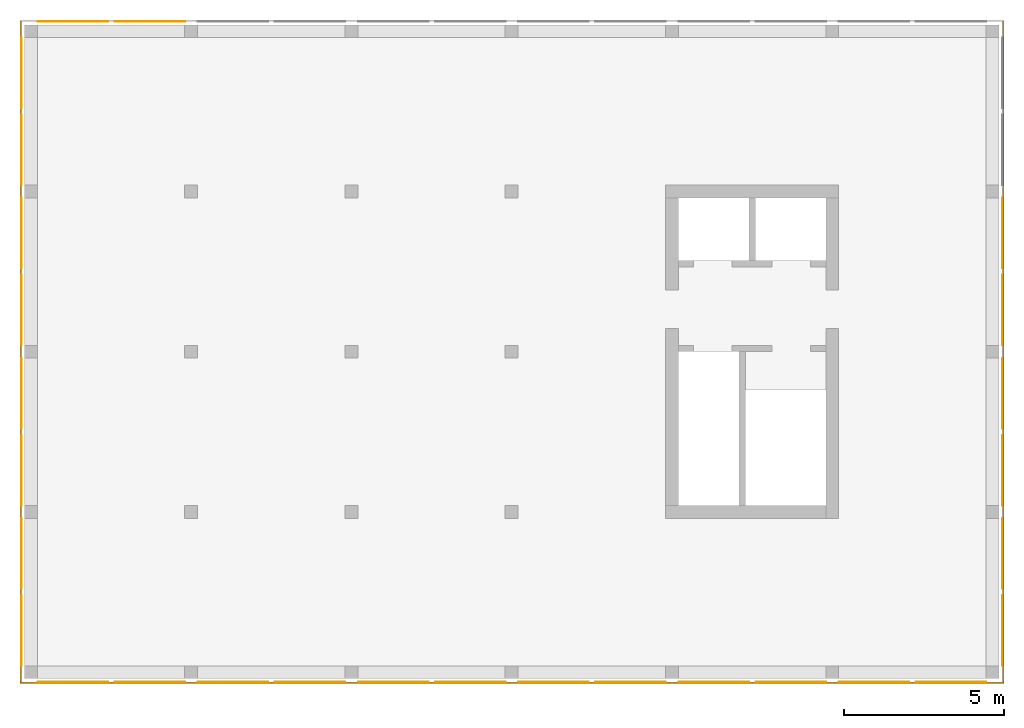
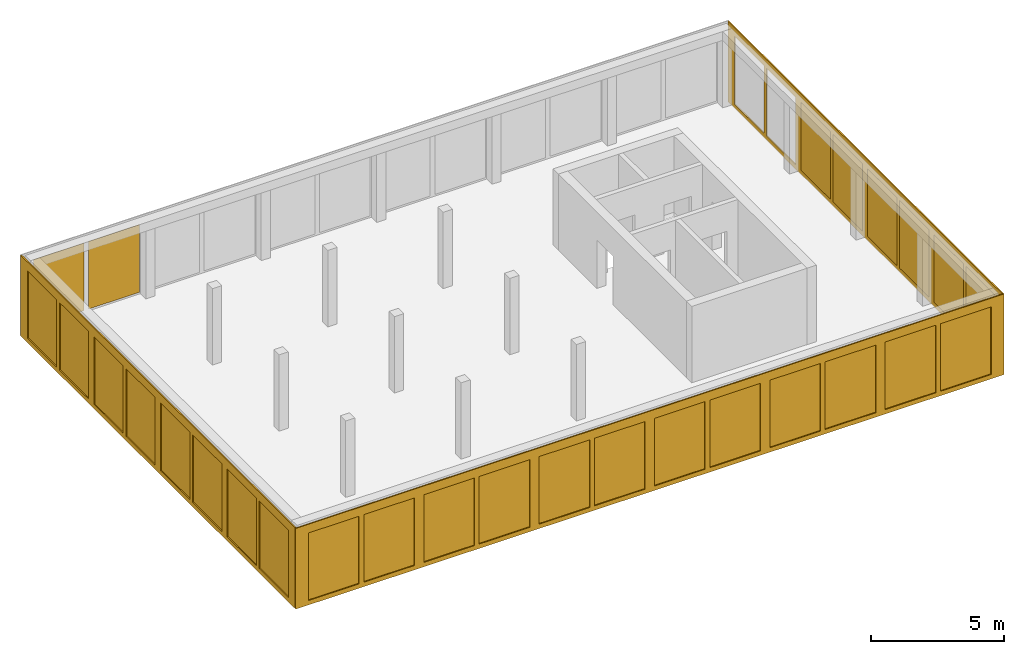
# One storey, part 2 of 3: 31 curtain walls.
"""IFC2X3 building model written with IfcOpenShell, lengths in metres."""

from ifc_helpers import new_model, entity, si_unit, converted_unit, frame, origin, place, context, subcontext, project, spatial, faceted_brep, material, element, save


model = new_model("IFC2X3")

# Units and contexts
model_context = context("Model", 3, precision=1e-05, world=origin())
body_context = subcontext(model_context, "Body", "Model", "MODEL_VIEW")
ifc_project = project(units=[si_unit("LENGTHUNIT", "METRE"), si_unit("AREAUNIT", "SQUARE_METRE"), si_unit("VOLUMEUNIT", "CUBIC_METRE"), si_unit("MASSUNIT", "GRAM", prefix="KILO"), converted_unit("PLANEANGLEUNIT", "DEGREE", entity("IfcPlaneAngleMeasure", 0.0174532925199433), si_unit("PLANEANGLEUNIT", "RADIAN"), dimensions=[0, 0, 0, 0, 0, 0, 0])], contexts=[model_context])

# Site, building, storey
site_placement = place(None, origin())
site = spatial("IfcSite", under=ifc_project, at=site_placement, CompositionType="ELEMENT")
building_placement = place(site_placement, origin())
building = spatial("IfcBuilding", under=site, at=building_placement, CompositionType="ELEMENT")
storey_placement = place(building_placement, frame((0.0, 0.0, 16.0)))
storey = spatial("IfcBuildingStorey", under=building, at=storey_placement, Name="4. Obergeschoss", CompositionType="ELEMENT", Elevation=16.0)

# Curtain walls
ifc_material_1 = material(Name="ALU")
curtain_wall_1_placement = place(storey_placement, frame((-0.139330706017223, -0.15, -0.2)))
element("IfcCurtainWall", 1, at=curtain_wall_1_placement, inside=storey, material=ifc_material_1, Name="Profil SN standard", context=body_context, shape_type="Brep", body=[
    faceted_brep([(30.7, 0.0500000000000003, 0.0), (0.0, 0.0500000000000003, 0.0), (0.0, 3.41060513164848e-16, 0.0), (30.7, 3.41060513164848e-16, 0.0), (0.0, 0.0500000000000004, 3.7), (30.7, 0.0500000000000003, 3.7), (30.7, 3.41060513164848e-16, 3.7), (0.0, 3.41060513164848e-16, 3.7), (25.15, 5.6843418860808e-17, 0.2), (25.15, 0.0500000000000001, 0.2), (25.15, 0.0500000000000001, 3.3), (25.15, 5.6843418860808e-17, 3.3), (25.55, 0.0500000000000001, 0.2), (25.55, 5.6843418860808e-17, 0.2), (25.55, 5.6843418860808e-17, 3.3), (25.55, 0.0500000000000001, 3.3), (20.15, 8.5265128291212e-17, 0.2), (20.15, 0.0500000000000001, 0.2), (20.15, 0.0500000000000001, 3.3), (20.15, 8.5265128291212e-17, 3.3), (20.55, 0.0500000000000001, 0.2), (20.55, 8.5265128291212e-17, 0.2), (20.55, 8.5265128291212e-17, 3.3), (20.55, 0.0500000000000001, 3.3), (30.15, 0.0, 0.2), (30.15, 0.05, 0.2), (30.15, 0.05, 3.3), (30.15, 0.0, 3.3), (22.75, 2.8421709430404e-16, 0.2), (22.75, 0.0500000000000003, 0.2), (22.75, 0.0500000000000003, 3.3), (22.75, 2.8421709430404e-16, 3.3), (22.95, 0.0500000000000003, 0.2), (22.95, 2.8421709430404e-16, 0.2), (22.95, 2.8421709430404e-16, 3.3), (22.95, 0.0500000000000003, 3.3), (17.75, 3.41060513164848e-16, 0.2), (17.75, 0.0500000000000003, 0.2), (17.75, 0.0500000000000003, 3.3), (17.75, 3.41060513164848e-16, 3.3), (17.95, 0.0500000000000003, 0.2), (17.95, 3.41060513164848e-16, 0.2), (17.95, 3.41060513164848e-16, 3.3), (17.95, 0.0500000000000003, 3.3), (27.75, 3.41060513164848e-16, 0.2), (27.75, 0.0500000000000003, 0.2), (27.75, 0.0500000000000003, 3.3), (27.75, 3.41060513164848e-16, 3.3), (27.95, 0.0500000000000003, 0.2), (27.95, 3.41060513164848e-16, 0.2), (27.95, 3.41060513164848e-16, 3.3), (27.95, 0.0500000000000003, 3.3), (2.75, 3.41060513164848e-16, 0.2), (2.75, 0.0500000000000003, 0.2), (2.75, 0.0500000000000003, 3.3), (2.75, 3.41060513164848e-16, 3.3), (2.95, 0.0500000000000003, 0.2), (2.95, 3.41060513164848e-16, 0.2), (2.95, 3.41060513164848e-16, 3.3), (2.95, 0.0500000000000003, 3.3), (12.75, 3.41060513164848e-16, 0.2), (12.75, 0.0500000000000003, 0.2), (12.75, 0.0500000000000003, 3.3), (12.75, 3.41060513164848e-16, 3.3), (12.95, 0.0500000000000003, 0.2), (12.95, 3.41060513164848e-16, 0.2), (12.95, 3.41060513164848e-16, 3.3), (12.95, 0.0500000000000003, 3.3), (7.75, 3.41060513164848e-16, 0.2), (7.75, 0.0500000000000003, 0.2), (7.75, 0.0500000000000003, 3.3), (7.75, 3.41060513164848e-16, 3.3), (7.95, 0.0500000000000003, 0.2), (7.95, 3.41060513164848e-16, 0.2), (7.95, 3.41060513164848e-16, 3.3), (7.95, 0.0500000000000003, 3.3), (15.55, 3.41060513164848e-16, 0.2), (15.55, 0.0500000000000003, 0.2), (15.55, 3.41060513164848e-16, 3.3), (15.55, 0.0500000000000003, 3.3), (10.55, 0.0500000000000002, 3.3), (10.55, 1.70530256582424e-16, 3.3), (15.15, 3.41060513164848e-16, 3.3), (15.15, 0.0500000000000003, 3.3), (15.15, 3.41060513164848e-16, 0.2), (15.15, 0.0500000000000003, 0.2), (10.55, 3.41060513164848e-16, 0.2), (10.55, 0.0500000000000003, 0.2), (0.550000000000004, 0.0500000000000003, 3.3), (0.550000000000004, 2.8421709430404e-16, 3.3), (5.15, 2.27373675443232e-16, 3.3), (5.15, 0.0500000000000003, 3.3), (5.15, 3.41060513164848e-16, 0.2), (5.15, 0.0500000000000003, 0.2), (0.550000000000004, 2.8421709430404e-16, 0.2), (0.550000000000004, 0.0500000000000003, 0.2), (5.55, 0.0500000000000003, 0.2), (5.55, 3.41060513164848e-16, 0.2), (5.55, 2.27373675443232e-16, 3.3), (5.55, 0.0500000000000003, 3.3), (10.15, 1.70530256582424e-16, 3.3), (10.15, 0.0500000000000002, 3.3), (10.15, 3.41060513164848e-16, 0.2), (10.15, 0.0500000000000003, 0.2)], [[[0, 1, 2, 3]], [[4, 5, 6, 7]], [[3, 6, 5, 0]], [[1, 4, 7, 2]], [[8, 9, 10, 11]], [[12, 13, 14, 15]], [[16, 17, 18, 19]], [[20, 21, 22, 23]], [[24, 25, 26, 27]], [[28, 29, 30, 31]], [[32, 33, 34, 35]], [[36, 37, 38, 39]], [[40, 41, 42, 43]], [[44, 45, 46, 47]], [[48, 49, 50, 51]], [[52, 53, 54, 55]], [[56, 57, 58, 59]], [[60, 61, 62, 63]], [[64, 65, 66, 67]], [[68, 69, 70, 71]], [[72, 73, 74, 75]], [[36, 76, 77, 37]], [[77, 76, 78, 79]], [[38, 79, 78, 39]], [[62, 80, 81, 63]], [[66, 82, 83, 67]], [[84, 85, 83, 82]], [[64, 85, 84, 65]], [[60, 86, 87, 61]], [[87, 86, 81, 80]], [[54, 88, 89, 55]], [[58, 90, 91, 59]], [[92, 93, 91, 90]], [[56, 93, 92, 57]], [[52, 94, 95, 53]], [[95, 94, 89, 88]], [[96, 97, 98, 99]], [[70, 99, 98, 71]], [[74, 100, 101, 75]], [[102, 103, 101, 100]], [[72, 103, 102, 73]], [[68, 97, 96, 69]], [[16, 41, 40, 17]], [[20, 29, 28, 21]], [[8, 33, 32, 9]], [[12, 45, 44, 13]], [[22, 31, 30, 23]], [[18, 43, 42, 19]], [[14, 47, 46, 15]], [[10, 35, 34, 11]], [[24, 49, 48, 25]], [[26, 51, 50, 27]], [[6, 3, 2, 7], [97, 68, 71, 98], [89, 94, 52, 55], [81, 86, 60, 63], [73, 102, 100, 74], [65, 84, 82, 66], [57, 92, 90, 58], [78, 76, 36, 39], [27, 50, 49, 24], [21, 28, 31, 22], [42, 41, 16, 19], [13, 44, 47, 14], [34, 33, 8, 11]], [[4, 1, 0, 5], [93, 56, 59, 91], [101, 103, 72, 75], [85, 64, 67, 83], [69, 96, 99, 70], [61, 87, 80, 62], [53, 95, 88, 54], [37, 77, 79, 38], [25, 48, 51, 26], [17, 40, 43, 18], [30, 29, 20, 23], [9, 32, 35, 10], [46, 45, 12, 15]]], orient=[[False], [False], [False], [False], [False], [False], [False], [False], [False], [False], [False], [False], [False], [False], [False], [False], [False], [False], [False], [False], [False], [False], [False], [False], [False], [False], [False], [False], [False], [False], [False], [False], [False], [False], [False], [False], [False], [False], [False], [False], [False], [False], [False], [False], [False], [False], [False], [False], [False], [False], [False], [False], [False, False, False, False, False, False, False, False, False, False, False, False, False], [False, False, False, False, False, False, False, False, False, False, False, False, False]]),
])
ifc_material_2 = material(Name="ALU")
curtain_wall_2_placement = place(storey_placement, frame((30.5106692939828, -0.1, -0.2)))
element("IfcCurtainWall", 2, at=curtain_wall_2_placement, inside=storey, material=ifc_material_2, Name="Profil OW standard", context=body_context, shape_type="Brep", body=[
    faceted_brep([(0.05, 20.6, 3.7), (0.05, 0.0, 3.7), (0.0, 0.0, 3.7), (0.0, 20.6, 3.7), (0.05, 0.0, 0.0), (0.05, 20.6, 0.0), (0.0, 20.6, 0.0), (0.0, 0.0, 0.0), (3.63797880709171e-15, 0.500000000000022, 0.2), (0.0500000000000036, 0.500000000000022, 0.2), (0.0500000000000036, 0.500000000000022, 3.3), (3.63797880709171e-15, 0.500000000000022, 3.3), (0.05, 2.70000000000003, 0.2), (0.0, 2.70000000000003, 0.2), (0.0, 2.70000000000003, 3.3), (0.05, 2.70000000000003, 3.3), (0.05, 2.90000000000003, 0.2), (0.05, 2.90000000000003, 3.3), (0.0, 2.90000000000003, 3.3), (0.0, 2.90000000000003, 0.2), (0.0, 7.70000000000003, 0.2), (0.0, 7.70000000000003, 3.3), (0.05, 7.70000000000003, 3.3), (0.05, 7.70000000000003, 0.2), (0.05, 7.90000000000003, 0.2), (0.05, 7.90000000000003, 3.3), (0.0, 7.90000000000003, 3.3), (0.0, 7.90000000000003, 0.2), (0.0, 12.7, 0.2), (0.0, 12.7, 3.3), (0.05, 12.7, 3.3), (0.05, 12.7, 0.2), (0.05, 12.9, 0.2), (0.05, 12.9, 3.3), (0.0, 12.9, 3.3), (0.0, 12.9, 0.2), (0.0, 5.50000000000002, 0.2), (0.05, 5.50000000000002, 0.2), (0.05, 5.10000000000002, 0.2), (0.0, 5.10000000000002, 0.2), (0.0, 5.10000000000002, 3.3), (0.05, 5.10000000000002, 3.3), (0.05, 5.50000000000002, 3.3), (0.0, 5.50000000000002, 3.3), (0.0, 10.5, 0.2), (0.05, 10.5, 0.2), (0.05, 10.1, 0.2), (0.0, 10.1, 0.2), (0.0, 10.1, 3.3), (0.05, 10.1, 3.3), (0.05, 10.5, 3.3), (0.0, 10.5, 3.3), (0.05, 15.1, 0.2), (0.0, 15.1, 0.2), (0.0, 15.1, 3.3), (0.05, 15.1, 3.3), (0.0, 15.5, 0.2), (0.05, 15.5, 0.2), (0.05, 15.5, 3.3), (0.0, 15.5, 3.3), (0.05, 20.1, 0.2), (0.0, 20.1, 0.2), (0.0, 20.1, 3.3), (0.05, 20.1, 3.3), (0.05, 17.7, 0.2), (0.0, 17.7, 0.2), (0.0, 17.9, 0.2), (0.05, 17.9, 0.2), (0.05, 17.9, 3.3), (0.0, 17.9, 3.3), (0.0, 17.7, 3.3), (0.05, 17.7, 3.3)], [[[0, 1, 2, 3]], [[4, 5, 6, 7]], [[8, 9, 10, 11]], [[7, 2, 1, 4]], [[12, 9, 8, 13]], [[14, 11, 10, 15]], [[13, 14, 15, 12]], [[16, 17, 18, 19]], [[20, 21, 22, 23]], [[24, 25, 26, 27]], [[28, 29, 30, 31]], [[32, 33, 34, 35]], [[36, 20, 23, 37]], [[38, 16, 19, 39]], [[40, 18, 17, 41]], [[42, 22, 21, 43]], [[36, 37, 42, 43]], [[38, 39, 40, 41]], [[44, 28, 31, 45]], [[46, 24, 27, 47]], [[48, 26, 25, 49]], [[50, 30, 29, 51]], [[44, 45, 50, 51]], [[46, 47, 48, 49]], [[52, 32, 35, 53]], [[54, 34, 33, 55]], [[56, 57, 58, 59]], [[52, 53, 54, 55]], [[5, 0, 3, 6]], [[60, 61, 62, 63]], [[64, 57, 56, 65]], [[66, 61, 60, 67]], [[68, 63, 62, 69]], [[70, 59, 58, 71]], [[65, 70, 71, 64]], [[67, 68, 69, 66]], [[2, 7, 6, 3], [13, 8, 11, 14], [39, 19, 18, 40], [21, 20, 36, 43], [47, 27, 26, 48], [29, 28, 44, 51], [53, 35, 34, 54], [65, 56, 59, 70], [62, 61, 66, 69]], [[4, 1, 0, 5], [15, 10, 9, 12], [41, 17, 16, 38], [23, 22, 42, 37], [49, 25, 24, 46], [31, 30, 50, 45], [33, 32, 52, 55], [67, 60, 63, 68], [58, 57, 64, 71]]], orient=[[False], [False], [False], [False], [False], [False], [False], [False], [False], [False], [False], [False], [False], [False], [False], [False], [False], [False], [False], [False], [False], [False], [False], [False], [False], [False], [False], [False], [False], [False], [False], [False], [False], [False], [False], [False], [False, False, False, False, False, False, False, False, False], [False, False, False, False, False, False, False, False, False]]),
])
ifc_material_3 = material(Name="ALU")
curtain_wall_3_placement = place(storey_placement, frame((-0.139330706017224, -0.1, -0.2)))
element("IfcCurtainWall", 3, at=curtain_wall_3_placement, inside=storey, material=ifc_material_3, Name="Profil OW standard", context=body_context, shape_type="Brep", body=[
    faceted_brep([(0.0500000000000026, 0.0, 0.0), (0.0500000000000026, 20.6, 0.0), (2.55795384873636e-15, 20.6, 0.0), (2.58637555816676e-15, 0.0, 0.0), (0.0500000000000026, 20.6, 3.7), (0.0500000000000026, 0.0, 3.7), (2.58637555816676e-15, 0.0, 3.7), (2.55795384873636e-15, 20.6, 3.7), (0.0500000000000012, 10.1, 0.2), (1.10844666778576e-15, 10.1, 0.2), (1.10844666778576e-15, 10.1, 3.3), (0.0500000000000012, 10.1, 3.3), (1.08002495835535e-15, 10.5, 0.2), (0.0500000000000011, 10.5, 0.2), (0.0500000000000011, 10.5, 3.3), (1.08002495835535e-15, 10.5, 3.3), (1.62003743753303e-15, 5.50000000000002, 0.2), (0.0500000000000017, 5.50000000000002, 0.2), (0.0500000000000017, 5.50000000000002, 3.3), (1.62003743753303e-15, 5.50000000000002, 3.3), (0.0500000000000017, 5.10000000000002, 0.2), (1.67688085639384e-15, 5.10000000000002, 0.2), (1.67688085639384e-15, 5.10000000000002, 3.3), (0.0500000000000017, 5.10000000000002, 3.3), (5.11590769747272e-16, 15.5, 0.2), (0.0500000000000005, 15.5, 0.2), (0.0500000000000005, 15.5, 3.3), (5.11590769747272e-16, 15.5, 3.3), (0.0500000000000006, 15.1, 0.2), (5.6843418860808e-16, 15.1, 0.2), (5.6843418860808e-16, 15.1, 3.3), (0.0500000000000006, 15.1, 3.3), (0.05, 20.1, 0.2), (0.0, 20.1, 0.2), (0.0, 20.1, 3.3), (0.05, 20.1, 3.3), (2.18847162614111e-15, 7.90000000000002, 0.2), (0.0500000000000022, 7.90000000000002, 0.2), (0.0500000000000022, 7.90000000000002, 3.3), (2.18847162614111e-15, 7.90000000000002, 3.3), (0.0500000000000023, 7.70000000000002, 0.2), (2.24531504500192e-15, 7.70000000000002, 0.2), (2.24531504500192e-15, 7.70000000000002, 3.3), (0.0500000000000023, 7.70000000000002, 3.3), (2.18847162614111e-15, 2.90000000000002, 0.2), (0.0500000000000022, 2.90000000000002, 0.2), (0.0500000000000022, 2.90000000000002, 3.3), (2.18847162614111e-15, 2.90000000000002, 3.3), (0.0500000000000023, 2.70000000000002, 0.2), (2.24531504500192e-15, 2.70000000000002, 0.2), (2.24531504500192e-15, 2.70000000000002, 3.3), (0.0500000000000023, 2.70000000000002, 3.3), (2.18847162614111e-15, 17.9, 0.2), (0.0500000000000022, 17.9, 0.2), (0.0500000000000022, 17.9, 3.3), (2.18847162614111e-15, 17.9, 3.3), (0.0500000000000023, 17.7, 0.2), (2.24531504500192e-15, 17.7, 0.2), (2.24531504500192e-15, 17.7, 3.3), (0.0500000000000023, 17.7, 3.3), (2.24531504500192e-15, 12.7, 3.3), (0.0500000000000023, 12.7, 3.3), (2.18847162614111e-15, 12.9, 3.3), (0.0500000000000022, 12.9, 3.3), (0.0500000000000022, 12.9, 0.2), (2.18847162614111e-15, 12.9, 0.2), (0.0500000000000023, 12.7, 0.2), (2.24531504500192e-15, 12.7, 0.2), (0.0500000000000026, 0.500000000000022, 0.2), (2.58637555816676e-15, 0.500000000000022, 0.2), (0.0500000000000026, 0.500000000000022, 3.3), (2.58637555816676e-15, 0.500000000000022, 3.3)], [[[0, 1, 2, 3]], [[4, 5, 6, 7]], [[8, 9, 10, 11]], [[12, 13, 14, 15]], [[3, 6, 5, 0]], [[16, 17, 18, 19]], [[20, 21, 22, 23]], [[1, 4, 7, 2]], [[24, 25, 26, 27]], [[28, 29, 30, 31]], [[32, 33, 34, 35]], [[36, 37, 38, 39]], [[40, 41, 42, 43]], [[44, 45, 46, 47]], [[48, 49, 50, 51]], [[52, 53, 54, 55]], [[56, 57, 58, 59]], [[60, 15, 14, 61]], [[30, 62, 63, 31]], [[26, 59, 58, 27]], [[34, 55, 54, 35]], [[32, 53, 52, 33]], [[24, 57, 56, 25]], [[28, 64, 65, 29]], [[66, 13, 12, 67]], [[36, 9, 8, 37]], [[16, 41, 40, 17]], [[20, 45, 44, 21]], [[48, 68, 69, 49]], [[69, 68, 70, 71]], [[50, 71, 70, 51]], [[22, 47, 46, 23]], [[18, 43, 42, 19]], [[38, 11, 10, 39]], [[65, 64, 63, 62]], [[66, 67, 60, 61]], [[2, 7, 6, 3], [69, 71, 50, 49], [39, 10, 9, 36], [33, 52, 55, 34], [29, 65, 62, 30], [58, 57, 24, 27], [19, 42, 41, 16], [44, 47, 22, 21], [60, 67, 12, 15]], [[0, 5, 4, 1], [51, 70, 68, 48], [13, 66, 61, 14], [35, 54, 53, 32], [31, 63, 64, 28], [56, 59, 26, 25], [23, 46, 45, 20], [40, 43, 18, 17], [38, 37, 8, 11]]], orient=[[False], [False], [False], [False], [False], [False], [False], [False], [False], [False], [False], [False], [False], [False], [False], [False], [False], [False], [False], [False], [False], [False], [False], [False], [False], [False], [False], [False], [False], [False], [False], [False], [False], [False], [False], [False], [False, False, False, False, False, False, False, False, False], [False, False, False, False, False, False, False, False, False]]),
])
ifc_material_4 = material(Name="VSG")
curtain_wall_4_placement = place(storey_placement, frame((30.5106692939828, 0.400000000000018, 0.0)))
element("IfcCurtainWall", 4, at=curtain_wall_4_placement, inside=storey, material=ifc_material_4, Name="standard", context=body_context, shape_type="Brep", body=[
    faceted_brep([(0.0, 0.0, 0.0), (0.0, 0.0, 3.1), (0.005, 0.0, 3.1), (0.005, 0.0, 0.0), (0.005, 2.2, 3.1), (0.005, 2.2, 0.0), (0.0, 2.2, 3.1), (0.0, 2.2, 0.0)], [[[0, 1, 2, 3]], [[3, 2, 4, 5]], [[5, 4, 6, 7]], [[7, 6, 1, 0]], [[6, 4, 2, 1]], [[0, 3, 5, 7]]], orient=[[False], [False], [False], [False], [False], [False]]),
])
ifc_material_5 = material(Name="VSG")
curtain_wall_5_placement = place(storey_placement, frame((-0.0943307060172242, 17.8, 0.0)))
element("IfcCurtainWall", 5, at=curtain_wall_5_placement, inside=storey, material=ifc_material_5, Name="standard", context=body_context, shape_type="Brep", body=[
    faceted_brep([(0.005, -3.63797880709171e-15, 0.0), (0.0, -3.63797880709171e-15, 0.0), (0.0, -3.63797880709171e-15, 3.1), (0.005, -3.63797880709171e-15, 3.1), (0.0, 2.2, 0.0), (0.0, 2.2, 3.1), (0.005, 2.2, 0.0), (0.005, 2.2, 3.1)], [[[0, 1, 2, 3]], [[1, 4, 5, 2]], [[4, 6, 7, 5]], [[6, 0, 3, 7]], [[7, 3, 2, 5]], [[0, 6, 4, 1]]], orient=[[False], [False], [False], [False], [False], [False]]),
])
ifc_material_6 = material(Name="VSG")
curtain_wall_6_placement = place(storey_placement, frame((-0.0943307060172219, 15.4, 0.0)))
element("IfcCurtainWall", 6, at=curtain_wall_6_placement, inside=storey, material=ifc_material_6, Name="standard", context=body_context, shape_type="Brep", body=[
    faceted_brep([(0.005, -1.81898940354586e-15, 0.0), (0.0, -1.81898940354586e-15, 0.0), (0.0, -1.81898940354586e-15, 3.1), (0.005, -1.81898940354586e-15, 3.1), (0.0, 2.2, 0.0), (0.0, 2.2, 3.1), (0.005, 2.2, 0.0), (0.005, 2.2, 3.1)], [[[0, 1, 2, 3]], [[1, 4, 5, 2]], [[4, 6, 7, 5]], [[6, 0, 3, 7]], [[7, 3, 2, 5]], [[0, 6, 4, 1]]], orient=[[False], [False], [False], [False], [False], [False]]),
])
ifc_material_7 = material(Name="VSG")
curtain_wall_7_placement = place(storey_placement, frame((-0.0943307060172236, 12.8, 0.0)))
element("IfcCurtainWall", 7, at=curtain_wall_7_placement, inside=storey, material=ifc_material_7, Name="standard", context=body_context, shape_type="Brep", body=[
    faceted_brep([(0.005, 0.0, 0.0), (0.0, 0.0, 0.0), (0.0, 0.0, 3.1), (0.005, 0.0, 3.1), (0.0, 2.2, 0.0), (0.0, 2.2, 3.1), (0.005, 2.2, 0.0), (0.005, 2.2, 3.1)], [[[0, 1, 2, 3]], [[1, 4, 5, 2]], [[4, 6, 7, 5]], [[6, 0, 3, 7]], [[7, 3, 2, 5]], [[0, 6, 4, 1]]], orient=[[False], [False], [False], [False], [False], [False]]),
])
ifc_material_8 = material(Name="VSG")
curtain_wall_8_placement = place(storey_placement, frame((-0.0943307060172219, 10.4, 0.0)))
element("IfcCurtainWall", 8, at=curtain_wall_8_placement, inside=storey, material=ifc_material_8, Name="standard", context=body_context, shape_type="Brep", body=[
    faceted_brep([(0.005, 0.0, 0.0), (0.0, 0.0, 0.0), (0.0, 0.0, 3.1), (0.005, 0.0, 3.1), (0.0, 2.2, 0.0), (0.0, 2.2, 3.1), (0.005, 2.2, 0.0), (0.005, 2.2, 3.1)], [[[0, 1, 2, 3]], [[1, 4, 5, 2]], [[4, 6, 7, 5]], [[6, 0, 3, 7]], [[7, 3, 2, 5]], [[0, 6, 4, 1]]], orient=[[False], [False], [False], [False], [False], [False]]),
])
ifc_material_9 = material(Name="VSG")
curtain_wall_9_placement = place(storey_placement, frame((-0.0943307060172231, 7.80000000000001, 0.0)))
element("IfcCurtainWall", 9, at=curtain_wall_9_placement, inside=storey, material=ifc_material_9, Name="standard", context=body_context, shape_type="Brep", body=[
    faceted_brep([(0.005, 0.0, 0.0), (0.0, 0.0, 0.0), (0.0, 0.0, 3.1), (0.005, 0.0, 3.1), (0.0, 2.2, 0.0), (0.0, 2.2, 3.1), (0.005, 2.2, 0.0), (0.005, 2.2, 3.1)], [[[0, 1, 2, 3]], [[1, 4, 5, 2]], [[4, 6, 7, 5]], [[6, 0, 3, 7]], [[7, 3, 2, 5]], [[0, 6, 4, 1]]], orient=[[False], [False], [False], [False], [False], [False]]),
])
ifc_material_10 = material(Name="VSG")
curtain_wall_10_placement = place(storey_placement, frame((-0.0943307060172219, 5.40000000000002, 0.0)))
element("IfcCurtainWall", 10, at=curtain_wall_10_placement, inside=storey, material=ifc_material_10, Name="standard", context=body_context, shape_type="Brep", body=[
    faceted_brep([(0.005, 0.0, 0.0), (0.0, 0.0, 0.0), (0.0, 0.0, 3.1), (0.005, 0.0, 3.1), (0.0, 2.2, 0.0), (0.0, 2.2, 3.1), (0.005, 2.2, 0.0), (0.005, 2.2, 3.1)], [[[0, 1, 2, 3]], [[1, 4, 5, 2]], [[4, 6, 7, 5]], [[6, 0, 3, 7]], [[7, 3, 2, 5]], [[0, 6, 4, 1]]], orient=[[False], [False], [False], [False], [False], [False]]),
])
ifc_material_11 = material(Name="VSG")
curtain_wall_11_placement = place(storey_placement, frame((-0.0943307060172225, 2.80000000000001, 0.0)))
element("IfcCurtainWall", 11, at=curtain_wall_11_placement, inside=storey, material=ifc_material_11, Name="standard", context=body_context, shape_type="Brep", body=[
    faceted_brep([(0.005, 0.0, 0.0), (0.0, 0.0, 0.0), (0.0, 0.0, 3.1), (0.005, 0.0, 3.1), (0.0, 2.2, 0.0), (0.0, 2.2, 3.1), (0.005, 2.2, 0.0), (0.005, 2.2, 3.1)], [[[0, 1, 2, 3]], [[1, 4, 5, 2]], [[4, 6, 7, 5]], [[6, 0, 3, 7]], [[7, 3, 2, 5]], [[0, 6, 4, 1]]], orient=[[False], [False], [False], [False], [False], [False]]),
])
ifc_material_12 = material(Name="VSG")
curtain_wall_12_placement = place(storey_placement, frame((-0.0943307060172219, 0.400000000000018, 0.0)))
element("IfcCurtainWall", 12, at=curtain_wall_12_placement, inside=storey, material=ifc_material_12, Name="standard", context=body_context, shape_type="Brep", body=[
    faceted_brep([(0.005, 0.0, 0.0), (0.0, 0.0, 0.0), (0.0, 0.0, 3.1), (0.005, 0.0, 3.1), (0.0, 2.2, 0.0), (0.0, 2.2, 3.1), (0.005, 2.2, 0.0), (0.005, 2.2, 3.1)], [[[0, 1, 2, 3]], [[1, 4, 5, 2]], [[4, 6, 7, 5]], [[6, 0, 3, 7]], [[7, 3, 2, 5]], [[0, 6, 4, 1]]], orient=[[False], [False], [False], [False], [False], [False]]),
])
ifc_material_13 = material(Name="VSG")
curtain_wall_13_placement = place(storey_placement, frame((0.410669293982781, -0.105, 0.0)))
element("IfcCurtainWall", 13, at=curtain_wall_13_placement, inside=storey, material=ifc_material_13, Name="standard", context=body_context, shape_type="Brep", body=[
    faceted_brep([(2.2, 0.00500000000000001, 0.0), (2.2, 1.4210854715202e-17, 0.0), (2.2, 1.4210854715202e-17, 3.1), (2.2, 0.00500000000000001, 3.1), (0.0, 2.8421709430404e-16, 0.0), (0.0, 2.8421709430404e-16, 3.1), (0.0, 0.00500000000000028, 0.0), (0.0, 0.00500000000000028, 3.1)], [[[0, 1, 2, 3]], [[1, 4, 5, 2]], [[4, 6, 7, 5]], [[6, 0, 3, 7]], [[7, 3, 2, 5]], [[0, 6, 4, 1]]], orient=[[False], [False], [False], [False], [False], [False]]),
])
ifc_material_14 = material(Name="VSG")
curtain_wall_14_placement = place(storey_placement, frame((2.81066929398278, -0.105, 0.0)))
element("IfcCurtainWall", 14, at=curtain_wall_14_placement, inside=storey, material=ifc_material_14, Name="standard", context=body_context, shape_type="Brep", body=[
    faceted_brep([(2.2, 0.00500000000000001, 0.0), (2.2, 1.4210854715202e-17, 0.0), (2.2, 1.4210854715202e-17, 3.1), (2.2, 0.00500000000000001, 3.1), (0.0, 2.8421709430404e-16, 0.0), (0.0, 2.8421709430404e-16, 3.1), (0.0, 0.00500000000000028, 0.0), (0.0, 0.00500000000000028, 3.1)], [[[0, 1, 2, 3]], [[1, 4, 5, 2]], [[4, 6, 7, 5]], [[6, 0, 3, 7]], [[7, 3, 2, 5]], [[0, 6, 4, 1]]], orient=[[False], [False], [False], [False], [False], [False]]),
])
ifc_material_15 = material(Name="VSG")
curtain_wall_15_placement = place(storey_placement, frame((5.41066929398277, -0.105, 0.0)))
element("IfcCurtainWall", 15, at=curtain_wall_15_placement, inside=storey, material=ifc_material_15, Name="standard", context=body_context, shape_type="Brep", body=[
    faceted_brep([(2.2, 0.00500000000000001, 0.0), (2.2, 1.4210854715202e-17, 0.0), (2.2, 1.4210854715202e-17, 3.1), (2.2, 0.00500000000000001, 3.1), (0.0, 2.8421709430404e-16, 0.0), (0.0, 2.8421709430404e-16, 3.1), (0.0, 0.00500000000000028, 0.0), (0.0, 0.00500000000000028, 3.1)], [[[0, 1, 2, 3]], [[1, 4, 5, 2]], [[4, 6, 7, 5]], [[6, 0, 3, 7]], [[7, 3, 2, 5]], [[0, 6, 4, 1]]], orient=[[False], [False], [False], [False], [False], [False]]),
])
ifc_material_16 = material(Name="VSG")
curtain_wall_16_placement = place(storey_placement, frame((7.81066929398278, -0.105, 0.0)))
element("IfcCurtainWall", 16, at=curtain_wall_16_placement, inside=storey, material=ifc_material_16, Name="standard", context=body_context, shape_type="Brep", body=[
    faceted_brep([(2.2, 0.00500000000000001, 0.0), (2.2, 1.4210854715202e-17, 0.0), (2.2, 1.4210854715202e-17, 3.1), (2.2, 0.00500000000000001, 3.1), (0.0, 2.8421709430404e-16, 0.0), (0.0, 2.8421709430404e-16, 3.1), (0.0, 0.00500000000000028, 0.0), (0.0, 0.00500000000000028, 3.1)], [[[0, 1, 2, 3]], [[1, 4, 5, 2]], [[4, 6, 7, 5]], [[6, 0, 3, 7]], [[7, 3, 2, 5]], [[0, 6, 4, 1]]], orient=[[False], [False], [False], [False], [False], [False]]),
])
ifc_material_17 = material(Name="VSG")
curtain_wall_17_placement = place(storey_placement, frame((10.4106692939828, -0.105, 0.0)))
element("IfcCurtainWall", 17, at=curtain_wall_17_placement, inside=storey, material=ifc_material_17, Name="standard", context=body_context, shape_type="Brep", body=[
    faceted_brep([(2.2, 0.00500000000000001, 0.0), (2.2, 1.4210854715202e-17, 0.0), (2.2, 1.4210854715202e-17, 3.1), (2.2, 0.00500000000000001, 3.1), (0.0, 2.8421709430404e-16, 0.0), (0.0, 2.8421709430404e-16, 3.1), (0.0, 0.00500000000000028, 0.0), (0.0, 0.00500000000000028, 3.1)], [[[0, 1, 2, 3]], [[1, 4, 5, 2]], [[4, 6, 7, 5]], [[6, 0, 3, 7]], [[7, 3, 2, 5]], [[0, 6, 4, 1]]], orient=[[False], [False], [False], [False], [False], [False]]),
])
ifc_material_18 = material(Name="VSG")
curtain_wall_18_placement = place(storey_placement, frame((12.8106692939828, -0.105, 0.0)))
element("IfcCurtainWall", 18, at=curtain_wall_18_placement, inside=storey, material=ifc_material_18, Name="standard", context=body_context, shape_type="Brep", body=[
    faceted_brep([(2.2, 0.00500000000000001, 0.0), (2.2, 1.4210854715202e-17, 0.0), (2.2, 1.4210854715202e-17, 3.1), (2.2, 0.00500000000000001, 3.1), (0.0, 2.8421709430404e-16, 0.0), (0.0, 2.8421709430404e-16, 3.1), (0.0, 0.00500000000000028, 0.0), (0.0, 0.00500000000000028, 3.1)], [[[0, 1, 2, 3]], [[1, 4, 5, 2]], [[4, 6, 7, 5]], [[6, 0, 3, 7]], [[7, 3, 2, 5]], [[0, 6, 4, 1]]], orient=[[False], [False], [False], [False], [False], [False]]),
])
ifc_material_19 = material(Name="VSG")
curtain_wall_19_placement = place(storey_placement, frame((15.4106692939828, -0.105, 0.0)))
element("IfcCurtainWall", 19, at=curtain_wall_19_placement, inside=storey, material=ifc_material_19, Name="standard", context=body_context, shape_type="Brep", body=[
    faceted_brep([(2.20000000000001, 0.00500000000000001, 0.0), (2.20000000000001, 1.4210854715202e-17, 0.0), (2.20000000000001, 1.4210854715202e-17, 3.1), (2.20000000000001, 0.00500000000000001, 3.1), (1.81898940354586e-15, 2.8421709430404e-16, 0.0), (1.81898940354586e-15, 2.8421709430404e-16, 3.1), (1.81898940354586e-15, 0.00500000000000028, 0.0), (1.81898940354586e-15, 0.00500000000000028, 3.1)], [[[0, 1, 2, 3]], [[1, 4, 5, 2]], [[4, 6, 7, 5]], [[6, 0, 3, 7]], [[7, 3, 2, 5]], [[0, 6, 4, 1]]], orient=[[False], [False], [False], [False], [False], [False]]),
])
ifc_material_20 = material(Name="VSG")
curtain_wall_20_placement = place(storey_placement, frame((17.8106692939828, -0.105, 0.0)))
element("IfcCurtainWall", 20, at=curtain_wall_20_placement, inside=storey, material=ifc_material_20, Name="standard", context=body_context, shape_type="Brep", body=[
    faceted_brep([(2.2, 0.00500000000000001, 0.0), (2.2, 1.4210854715202e-17, 0.0), (2.2, 1.4210854715202e-17, 3.1), (2.2, 0.00500000000000001, 3.1), (0.0, 2.8421709430404e-16, 0.0), (0.0, 2.8421709430404e-16, 3.1), (0.0, 0.00500000000000028, 0.0), (0.0, 0.00500000000000028, 3.1)], [[[0, 1, 2, 3]], [[1, 4, 5, 2]], [[4, 6, 7, 5]], [[6, 0, 3, 7]], [[7, 3, 2, 5]], [[0, 6, 4, 1]]], orient=[[False], [False], [False], [False], [False], [False]]),
])
ifc_material_21 = material(Name="VSG")
curtain_wall_21_placement = place(storey_placement, frame((20.4106692939828, -0.105000000000001, 0.0)))
element("IfcCurtainWall", 21, at=curtain_wall_21_placement, inside=storey, material=ifc_material_21, Name="standard", context=body_context, shape_type="Brep", body=[
    faceted_brep([(2.2, 0.00500000000000001, 0.0), (2.2, 1.4210854715202e-17, 0.0), (2.2, 1.4210854715202e-17, 3.1), (2.2, 0.00500000000000001, 3.1), (0.0, 2.8421709430404e-16, 0.0), (0.0, 2.8421709430404e-16, 3.1), (0.0, 0.00500000000000028, 0.0), (0.0, 0.00500000000000028, 3.1)], [[[0, 1, 2, 3]], [[1, 4, 5, 2]], [[4, 6, 7, 5]], [[6, 0, 3, 7]], [[7, 3, 2, 5]], [[0, 6, 4, 1]]], orient=[[False], [False], [False], [False], [False], [False]]),
])
ifc_material_22 = material(Name="VSG")
curtain_wall_22_placement = place(storey_placement, frame((22.8106692939828, -0.105, 0.0)))
element("IfcCurtainWall", 22, at=curtain_wall_22_placement, inside=storey, material=ifc_material_22, Name="standard", context=body_context, shape_type="Brep", body=[
    faceted_brep([(2.2, 0.00500000000000001, 0.0), (2.2, 1.4210854715202e-17, 0.0), (2.2, 1.4210854715202e-17, 3.1), (2.2, 0.00500000000000001, 3.1), (0.0, 2.8421709430404e-16, 0.0), (0.0, 2.8421709430404e-16, 3.1), (0.0, 0.00500000000000028, 0.0), (0.0, 0.00500000000000028, 3.1)], [[[0, 1, 2, 3]], [[1, 4, 5, 2]], [[4, 6, 7, 5]], [[6, 0, 3, 7]], [[7, 3, 2, 5]], [[0, 6, 4, 1]]], orient=[[False], [False], [False], [False], [False], [False]]),
])
ifc_material_23 = material(Name="VSG")
curtain_wall_23_placement = place(storey_placement, frame((25.4106692939828, -0.105000000000001, 0.0)))
element("IfcCurtainWall", 23, at=curtain_wall_23_placement, inside=storey, material=ifc_material_23, Name="standard", context=body_context, shape_type="Brep", body=[
    faceted_brep([(2.2, 0.00500000000000001, 0.0), (2.2, 1.4210854715202e-17, 0.0), (2.2, 1.4210854715202e-17, 3.1), (2.2, 0.00500000000000001, 3.1), (0.0, 2.8421709430404e-16, 0.0), (0.0, 2.8421709430404e-16, 3.1), (0.0, 0.00500000000000028, 0.0), (0.0, 0.00500000000000028, 3.1)], [[[0, 1, 2, 3]], [[1, 4, 5, 2]], [[4, 6, 7, 5]], [[6, 0, 3, 7]], [[7, 3, 2, 5]], [[0, 6, 4, 1]]], orient=[[False], [False], [False], [False], [False], [False]]),
])
ifc_material_24 = material(Name="VSG")
curtain_wall_24_placement = place(storey_placement, frame((27.8106692939828, -0.105, 0.0)))
element("IfcCurtainWall", 24, at=curtain_wall_24_placement, inside=storey, material=ifc_material_24, Name="standard", context=body_context, shape_type="Brep", body=[
    faceted_brep([(2.2, 0.00500000000000001, 0.0), (2.2, 1.4210854715202e-17, 0.0), (2.2, 1.4210854715202e-17, 3.1), (2.2, 0.00500000000000001, 3.1), (0.0, 2.8421709430404e-16, 0.0), (0.0, 2.8421709430404e-16, 3.1), (0.0, 0.00500000000000028, 0.0), (0.0, 0.00500000000000028, 3.1)], [[[0, 1, 2, 3]], [[1, 4, 5, 2]], [[4, 6, 7, 5]], [[6, 0, 3, 7]], [[7, 3, 2, 5]], [[0, 6, 4, 1]]], orient=[[False], [False], [False], [False], [False], [False]]),
])
ifc_material_25 = material(Name="VSG")
curtain_wall_25_placement = place(storey_placement, frame((0.410669293982781, 20.5, 0.0)))
element("IfcCurtainWall", 25, at=curtain_wall_25_placement, inside=storey, material=ifc_material_25, Name="standard", context=body_context, shape_type="Brep", body=[
    faceted_brep([(2.2, 0.0, 0.0), (2.2, 0.0, 3.1), (2.2, 0.005, 3.1), (2.2, 0.005, 0.0), (0.0, 0.005, 3.1), (0.0, 0.005, 0.0), (0.0, 0.0, 3.1), (0.0, 0.0, 0.0)], [[[0, 1, 2, 3]], [[3, 2, 4, 5]], [[5, 4, 6, 7]], [[7, 6, 1, 0]], [[6, 4, 2, 1]], [[0, 3, 5, 7]]], orient=[[False], [False], [False], [False], [False], [False]]),
])
ifc_material_26 = material(Name="VSG")
curtain_wall_26_placement = place(storey_placement, frame((2.81066929398278, 20.5, 0.0)))
element("IfcCurtainWall", 26, at=curtain_wall_26_placement, inside=storey, material=ifc_material_26, Name="standard", context=body_context, shape_type="Brep", body=[
    faceted_brep([(2.2, 0.0, 0.0), (2.2, 0.0, 3.1), (2.2, 0.005, 3.1), (2.2, 0.005, 0.0), (0.0, 0.005, 3.1), (0.0, 0.005, 0.0), (0.0, 0.0, 3.1), (0.0, 0.0, 0.0)], [[[0, 1, 2, 3]], [[3, 2, 4, 5]], [[5, 4, 6, 7]], [[7, 6, 1, 0]], [[6, 4, 2, 1]], [[0, 3, 5, 7]]], orient=[[False], [False], [False], [False], [False], [False]]),
])
ifc_material_27 = material(Name="VSG")
curtain_wall_27_placement = place(storey_placement, frame((30.5106692939828, 12.8, 0.0)))
element("IfcCurtainWall", 27, at=curtain_wall_27_placement, inside=storey, material=ifc_material_27, Name="standard", context=body_context, shape_type="Brep", body=[
    faceted_brep([(0.0, 0.0, 0.0), (0.0, 0.0, 3.1), (0.005, 0.0, 3.1), (0.005, 0.0, 0.0), (0.005, 2.2, 3.1), (0.005, 2.2, 0.0), (0.0, 2.2, 3.1), (0.0, 2.2, 0.0)], [[[0, 1, 2, 3]], [[3, 2, 4, 5]], [[5, 4, 6, 7]], [[7, 6, 1, 0]], [[6, 4, 2, 1]], [[0, 3, 5, 7]]], orient=[[False], [False], [False], [False], [False], [False]]),
])
ifc_material_28 = material(Name="VSG")
curtain_wall_28_placement = place(storey_placement, frame((30.5106692939828, 10.4, 0.0)))
element("IfcCurtainWall", 28, at=curtain_wall_28_placement, inside=storey, material=ifc_material_28, Name="standard", context=body_context, shape_type="Brep", body=[
    faceted_brep([(0.0, 0.0, 0.0), (0.0, 0.0, 3.1), (0.005, 0.0, 3.1), (0.005, 0.0, 0.0), (0.005, 2.2, 3.1), (0.005, 2.2, 0.0), (0.0, 2.2, 3.1), (0.0, 2.2, 0.0)], [[[0, 1, 2, 3]], [[3, 2, 4, 5]], [[5, 4, 6, 7]], [[7, 6, 1, 0]], [[6, 4, 2, 1]], [[0, 3, 5, 7]]], orient=[[False], [False], [False], [False], [False], [False]]),
])
ifc_material_29 = material(Name="VSG")
curtain_wall_29_placement = place(storey_placement, frame((30.5106692939828, 7.80000000000001, 0.0)))
element("IfcCurtainWall", 29, at=curtain_wall_29_placement, inside=storey, material=ifc_material_29, Name="standard", context=body_context, shape_type="Brep", body=[
    faceted_brep([(0.0, 0.0, 0.0), (0.0, 0.0, 3.1), (0.005, 0.0, 3.1), (0.005, 0.0, 0.0), (0.005, 2.2, 3.1), (0.005, 2.2, 0.0), (0.0, 2.2, 3.1), (0.0, 2.2, 0.0)], [[[0, 1, 2, 3]], [[3, 2, 4, 5]], [[5, 4, 6, 7]], [[7, 6, 1, 0]], [[6, 4, 2, 1]], [[0, 3, 5, 7]]], orient=[[False], [False], [False], [False], [False], [False]]),
])
ifc_material_30 = material(Name="VSG")
curtain_wall_30_placement = place(storey_placement, frame((30.5106692939828, 5.40000000000002, 0.0)))
element("IfcCurtainWall", 30, at=curtain_wall_30_placement, inside=storey, material=ifc_material_30, Name="standard", context=body_context, shape_type="Brep", body=[
    faceted_brep([(0.0, 0.0, 0.0), (0.0, 0.0, 3.1), (0.005, 0.0, 3.1), (0.005, 0.0, 0.0), (0.005, 2.2, 3.1), (0.005, 2.2, 0.0), (0.0, 2.2, 3.1), (0.0, 2.2, 0.0)], [[[0, 1, 2, 3]], [[3, 2, 4, 5]], [[5, 4, 6, 7]], [[7, 6, 1, 0]], [[6, 4, 2, 1]], [[0, 3, 5, 7]]], orient=[[False], [False], [False], [False], [False], [False]]),
])
ifc_material_31 = material(Name="VSG")
curtain_wall_31_placement = place(storey_placement, frame((30.5106692939828, 2.80000000000001, 0.0)))
element("IfcCurtainWall", 31, at=curtain_wall_31_placement, inside=storey, material=ifc_material_31, Name="standard", context=body_context, shape_type="Brep", body=[
    faceted_brep([(0.0, 0.0, 0.0), (0.0, 0.0, 3.1), (0.005, 0.0, 3.1), (0.005, 0.0, 0.0), (0.005, 2.2, 3.1), (0.005, 2.2, 0.0), (0.0, 2.2, 3.1), (0.0, 2.2, 0.0)], [[[0, 1, 2, 3]], [[3, 2, 4, 5]], [[5, 4, 6, 7]], [[7, 6, 1, 0]], [[6, 4, 2, 1]], [[0, 3, 5, 7]]], orient=[[False], [False], [False], [False], [False], [False]]),
])

save(model, "model.ifc")
